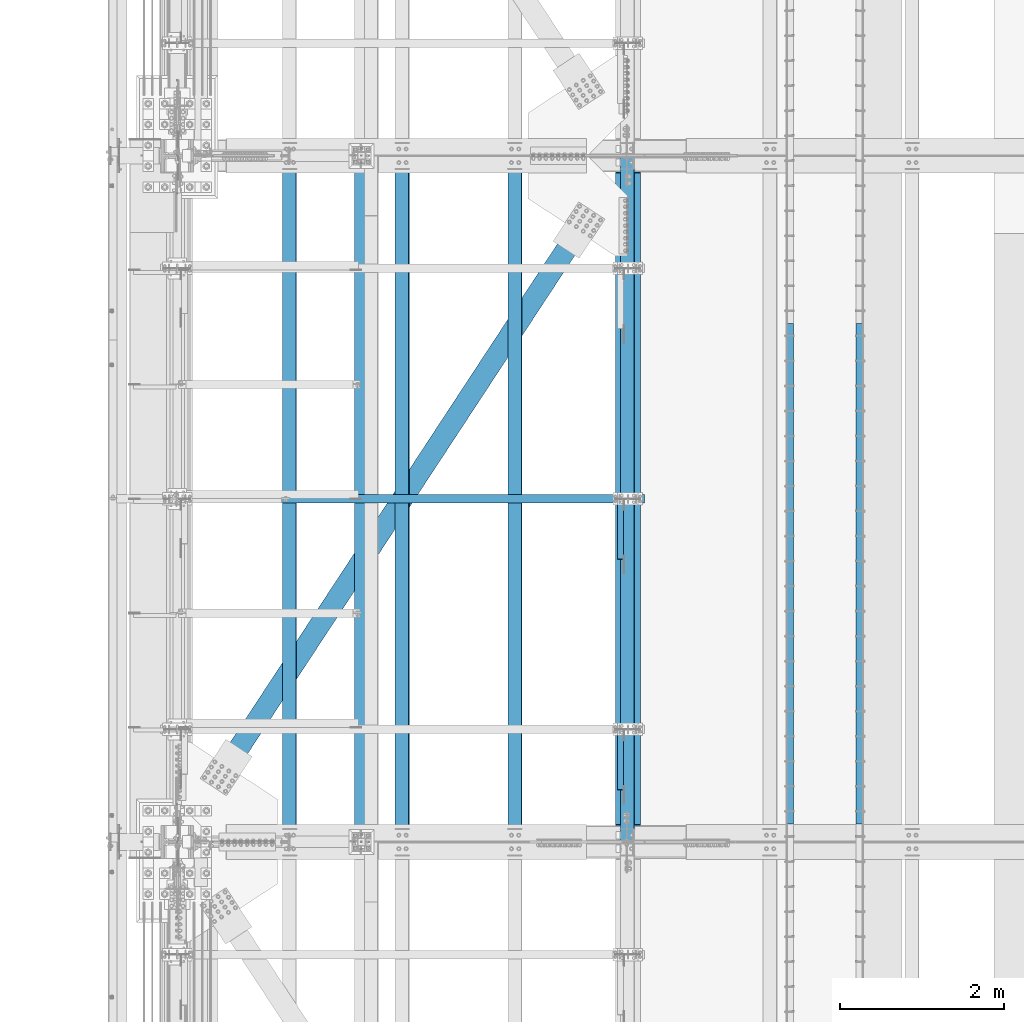
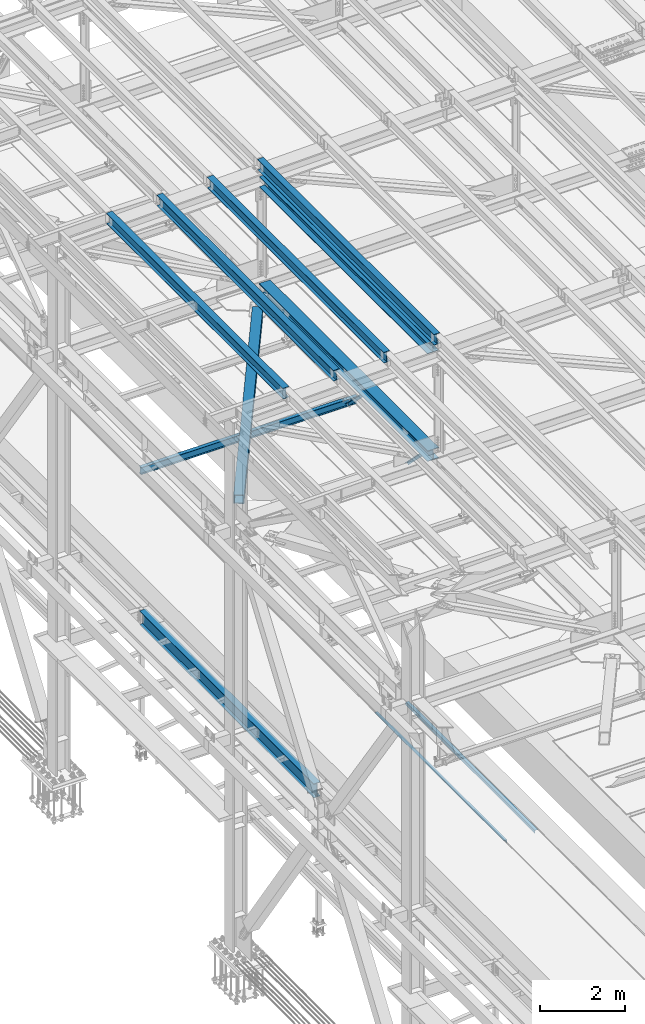
# One storey, part 1821 of 3843: 11 beams, 2 members, 13 elements without a shape of their own.
"""IFC2X3 building model written with IfcOpenShell, lengths in millimetres."""

from ifc_helpers import new_model, si_unit, frame, origin_with_axes, place, context, subcontext, project, spatial, faceted_brep, material, type_object, element, aggregate, save


model = new_model("IFC2X3")

# Units and contexts
model_context = context("Model", 3, precision=1e-05, world=origin_with_axes())
body_context = subcontext(model_context, "Body", "Model", "MODEL_VIEW")
ifc_project = project(units=[si_unit("LENGTHUNIT", "METRE", prefix="MILLI"), si_unit("AREAUNIT", "SQUARE_METRE"), si_unit("VOLUMEUNIT", "CUBIC_METRE"), si_unit("MASSUNIT", "GRAM", prefix="KILO"), si_unit("TIMEUNIT", "SECOND"), si_unit("PLANEANGLEUNIT", "RADIAN"), si_unit("SOLIDANGLEUNIT", "STERADIAN"), si_unit("THERMODYNAMICTEMPERATUREUNIT", "DEGREE_CELSIUS"), si_unit("LUMINOUSINTENSITYUNIT", "LUMEN")], contexts=[model_context])

# Site, building, storey
site_placement = place(None, origin_with_axes())
site = spatial("IfcSite", under=ifc_project, at=site_placement, CompositionType="ELEMENT")
building_placement = place(site_placement, origin_with_axes())
building = spatial("IfcBuilding", under=site, at=building_placement, Name="Undefined", CompositionType="ELEMENT")
storey_placement = place(building_placement, origin_with_axes())
storey = spatial("IfcBuildingStorey", under=building, at=storey_placement, Name="Undefined", CompositionType="ELEMENT", Elevation=0.0)

# Assembly, beam
assembly_1_placement = place(storey_placement, origin_with_axes())
assembly_1 = element("IfcElementAssembly", 1, at=assembly_1_placement, inside=storey, Name="EMBED_ANGLE", AssemblyPlace="NOTDEFINED", PredefinedType="RIGID_FRAME")
ifc_material_1 = material(Name="STEEL/A36")
beam_type_1 = type_object("IfcBeamType", Name="L3-1/2X3-1/2X5/16", PredefinedType="NOTDEFINED")
beam_1_placement = place(assembly_1_placement, frame((44887.896, 65230.375, 30419.675), z_axis=(0.0, 0.0, -1.0), x_axis=(0.0, -1.0, 0.0)))
beam_1 = element("IfcBeam", 2, at=beam_1_placement, type_object=beam_type_1, material=ifc_material_1, Name="EMBED_ANGLE", ObjectType="L3-1/2X3-1/2X5/16", context=body_context, shape_type="Brep", body=[
    faceted_brep([(-3.63797880709171e-12, 44.4499999999971, -44.4500000000007), (-3.63797880709171e-12, 44.4499999999971, 44.4500000000007), (6096.0, 44.4499999999971, 44.4500000000007), (6096.0, 44.4499999999971, -44.4500000000007), (-3.63797880709171e-12, 36.5124999999971, 44.4500000000007), (6096.0, 36.5124999999971, 44.4500000000007), (-3.63797880709171e-12, 36.5124999999971, -36.5125000000007), (6096.0, 36.5124999999971, -36.5125000000007), (3.63797880709171e-12, -44.4499999999971, -36.5125000000007), (6096.0, -44.4499999999971, -36.5125000000007), (3.63797880709171e-12, -44.4499999999971, -44.4500000000007), (6096.0, -44.4499999999971, -44.4500000000007)], [[[0, 1, 2, 3]], [[1, 4, 5, 2]], [[4, 6, 7, 5]], [[6, 8, 9, 7]], [[8, 10, 11, 9]], [[10, 0, 3, 11]], [[5, 7, 9, 11, 3, 2]], [[10, 8, 6, 4, 1, 0]]]),
])
aggregate(assembly_1, [beam_1])

assembly_2_placement = place(storey_placement, origin_with_axes())
assembly_2 = element("IfcElementAssembly", 3, at=assembly_2_placement, inside=storey, Name="EMBED_ANGLE", AssemblyPlace="NOTDEFINED", PredefinedType="RIGID_FRAME")
beam_2_placement = place(assembly_2_placement, frame((44036.996, 59134.375, 30419.675), z_axis=(0.0, 0.0, -1.0), x_axis=(0.0, 1.0, 0.0)))
beam_2 = element("IfcBeam", 4, at=beam_2_placement, type_object=beam_type_1, material=ifc_material_1, Name="EMBED_ANGLE", ObjectType="L3-1/2X3-1/2X5/16", context=body_context, shape_type="Brep", body=[
    faceted_brep([(-3.63797880709171e-12, 44.4499999999971, -44.4500000000007), (-3.63797880709171e-12, 44.4499999999971, 44.4500000000007), (6096.0, 44.4499999999971, 44.4500000000007), (6096.0, 44.4499999999971, -44.4500000000007), (-3.63797880709171e-12, 36.5124999999971, 44.4500000000007), (6096.0, 36.5124999999971, 44.4500000000007), (-3.63797880709171e-12, 36.5124999999971, -36.5125000000007), (6096.0, 36.5124999999971, -36.5125000000007), (3.63797880709171e-12, -44.4499999999971, -36.5125000000007), (6096.0, -44.4499999999971, -36.5125000000007), (3.63797880709171e-12, -44.4499999999971, -44.4500000000007), (6096.0, -44.4499999999971, -44.4500000000007)], [[[0, 1, 2, 3]], [[1, 4, 5, 2]], [[4, 6, 7, 5]], [[6, 8, 9, 7]], [[8, 10, 11, 9]], [[10, 0, 3, 11]], [[5, 7, 9, 11, 3, 2]], [[10, 8, 6, 4, 1, 0]]]),
])
aggregate(assembly_2, [beam_2])

assembly_3_placement = place(storey_placement, origin_with_axes())
assembly_3 = element("IfcElementAssembly", 5, at=assembly_3_placement, inside=storey, Name="BEAM", AssemblyPlace="NOTDEFINED", PredefinedType="RIGID_FRAME")
ifc_material_2 = material(Name="STEEL/A992")
beam_type_2 = type_object("IfcBeamType", Name="W12X26", PredefinedType="NOTDEFINED")
beam_3_placement = place(assembly_3_placement, frame((42059.1092623547, 58915.3115123161, 45721.2578981457), z_axis=(-0.0211520980636923, 7.39979999707428e-05, 0.999776266607585), x_axis=(2.20000000365173e-08, 0.99999999726089, -7.40150000196403e-05)))
beam_3 = element("IfcBeam", 6, at=beam_3_placement, type_object=beam_type_2, material=ifc_material_2, Name="BEAM", ObjectType="W12X26", context=body_context, shape_type="Brep", body=[
    faceted_brep([(12.700127520533, 82.5499999994863, -155.575000000135), (12.6994226809475, 82.5499999995009, -146.050000000127), (8343.89944555684, 82.5499999785316, -146.049999991839), (8343.90012297995, 82.5500000002939, -155.575000022138), (12.6993001598748, 3.17499999966822, -146.050000000112), (8343.89932303577, 3.17499997869163, -146.049999991832), (12.6776850792739, 3.17500000025757, 146.050000000127), (8343.87770795517, 3.17499997927371, 146.050000008421), (12.6778076003466, 82.5500000000975, 146.050000000127), (8343.87783047623, 82.5499999791282, 146.050000008399), (12.677102760761, 82.5500000001193, 155.575000000135), (8343.87712563665, 82.5499999791427, 155.575000008423), (12.6768479169405, -82.5499999995591, 155.575000000157), (8343.87687079283, -82.5500000205429, 155.575000008437), (12.6775527565187, -82.5499999995809, 146.050000000148), (8343.87757563241, -82.5500000205502, 146.050000008436), (12.6776752775913, -3.17499999974098, 146.050000000134), (8343.87769815348, -3.17500002070301, 146.050000008421), (12.6992903581922, -3.17500000032305, -146.050000000112), (8343.89931323408, -3.17500002129964, -146.049999991832), (12.6991678371196, -82.5500000001703, -146.050000000097), (8343.899190713, -82.5500000211468, -146.04999999181), (12.6998726767124, -82.5500000001921, -155.575000000106), (8343.89993364123, -82.5499999997992, -155.575000026431)], [[[0, 1, 2, 3]], [[1, 4, 5, 2]], [[4, 6, 7, 5]], [[6, 8, 9, 7]], [[8, 10, 11, 9]], [[10, 12, 13, 11]], [[12, 14, 15, 13]], [[14, 16, 17, 15]], [[16, 18, 19, 17]], [[18, 20, 21, 19]], [[20, 22, 23, 21]], [[22, 0, 3, 23]], [[5, 7, 9, 11, 13, 15, 17, 19, 21, 23, 3, 2]], [[22, 20, 18, 16, 14, 12, 10, 8, 6, 4, 1, 0]]]),
])
aggregate(assembly_3, [beam_3])

assembly_4_placement = place(storey_placement, origin_with_axes())
assembly_4 = element("IfcElementAssembly", 7, at=assembly_4_placement, inside=storey, Name="BEAM", AssemblyPlace="NOTDEFINED", PredefinedType="RIGID_FRAME")
beam_4_placement = place(assembly_4_placement, frame((40687.5092579516, 58915.3100417598, 45684.997575424), z_axis=(-0.0211520980514033, 6.45460000159801e-05, 0.99977626726275), x_axis=(9.99999685702628e-10, 0.999999997915939, -6.4560999994713e-05)))
beam_4 = element("IfcBeam", 8, at=beam_4_placement, type_object=beam_type_2, material=ifc_material_2, Name="BEAM", ObjectType="W12X26", context=body_context, shape_type="Brep", body=[
    faceted_brep([(12.70011274836, 82.5499999994863, -155.57500000039), (12.6994979422379, 82.5499999995081, -146.050000000389), (8343.89951535721, 82.5500000257598, -146.049999983188), (8343.90012297995, 82.5500000002939, -155.575000022138), (12.699389626614, 3.17499999963911, -146.050000000141), (8343.89940704162, 3.17500002588349, -146.049999982948), (12.6805355721299, 3.17500000042492, 146.05000000017), (8343.88055298712, 3.17500002667657, 146.050000017363), (12.6806438877466, 82.5500000003012, 146.049999999923), (8343.88066130275, 82.5500000265529, 146.050000017116), (12.6800290816172, 82.5500000003303, 155.574999999932), (8343.88004649661, 82.5500000265747, 155.575000017125), (12.6798037851258, -82.5499999994063, 155.575000000455), (8343.87982120013, -82.5499999731546, 155.575000017634), (12.6804185912551, -82.5499999994281, 146.050000000432), (8343.88043600626, -82.549999973191, 146.050000017625), (12.6805269068718, -3.17499999955908, 146.050000000192), (8343.88054432188, -3.17499997330742, 146.050000017378), (12.6993809613632, -3.17500000034488, -146.050000000119), (8343.89939837637, -3.17499997410778, -146.049999982919), (12.6992726457465, -82.5500000002212, -146.049999999872), (8343.89929006073, -82.5499999739768, -146.049999982679), (12.6998726767124, -82.5500000001921, -155.575000000106), (8343.89993364123, -82.5499999997992, -155.575000026431)], [[[0, 1, 2, 3]], [[1, 4, 5, 2]], [[4, 6, 7, 5]], [[6, 8, 9, 7]], [[8, 10, 11, 9]], [[10, 12, 13, 11]], [[12, 14, 15, 13]], [[14, 16, 17, 15]], [[16, 18, 19, 17]], [[18, 20, 21, 19]], [[20, 22, 23, 21]], [[22, 0, 3, 23]], [[5, 7, 9, 11, 13, 15, 17, 19, 21, 23, 3, 2]], [[22, 20, 18, 16, 14, 12, 10, 8, 6, 4, 1, 0]]]),
])
aggregate(assembly_4, [beam_4])

assembly_5_placement = place(storey_placement, origin_with_axes())
assembly_5 = element("IfcElementAssembly", 9, at=assembly_5_placement, inside=storey, Name="BEAM", AssemblyPlace="NOTDEFINED", PredefinedType="RIGID_FRAME")
beam_5_placement = place(assembly_5_placement, frame((39315.9092623368, 58915.2268657565, 45644.0366616244), z_axis=(-0.0211520983455921, -0.000470089999922493, 0.999776158823049), x_axis=(0.0, 0.999999889458325, 0.000470195000215701)))
beam_5 = element("IfcBeam", 10, at=beam_5_placement, type_object=beam_type_2, material=ifc_material_2, Name="BEAM", ObjectType="W12X26", context=body_context, shape_type="Brep", body=[
    faceted_brep([(12.6991634509395, 82.5499999998428, -155.574999999844), (12.70365802179, 82.5500000002357, -146.050000000047), (8343.90457893425, 82.5499999999229, -146.049999985342), (8343.90012297995, 82.5500000002939, -155.575000022138), (12.7044474549184, 3.17500000038126, -146.050000000047), (8343.90536836737, 3.17500000006839, -146.049999985342), (12.8417607012379, 3.17499999960273, 146.05000000009), (8344.04268161369, 3.17499999928987, 146.050000014802), (12.8409712681168, 82.5499999994499, 146.050000000097), (8344.04189218057, 82.5499999991443, 146.050000014802), (12.8454488739662, 82.5499999994354, 155.575000000099), (8344.04636978642, 82.5499999991225, 155.575000014811), (12.8470908948802, -82.5500000002648, 155.575000000099), (8344.04801180735, -82.5500000005704, 155.575000014811), (12.8426132890236, -82.5500000002285, 146.05000000009), (8344.04353420148, -82.5500000005413, 146.050000014802), (12.8418238558879, -3.17500000038126, 146.050000000097), (8344.04274476835, -3.17500000069413, 146.050000014802), (12.7045106095684, -3.17499999960273, -146.050000000047), (8343.90543152201, -3.17499999990832, -146.049999985342), (12.705300042704, -82.5499999994572, -146.050000000054), (8343.90622095515, -82.5499999997701, -146.049999985342), (12.700839471705, -82.5500000010798, -155.574999999444), (8343.90174334928, -82.549999999741, -155.574999985343)], [[[0, 1, 2, 3]], [[1, 4, 5, 2]], [[4, 6, 7, 5]], [[6, 8, 9, 7]], [[8, 10, 11, 9]], [[10, 12, 13, 11]], [[12, 14, 15, 13]], [[14, 16, 17, 15]], [[16, 18, 19, 17]], [[18, 20, 21, 19]], [[20, 22, 23, 21]], [[22, 0, 3, 23]], [[5, 7, 9, 11, 13, 15, 17, 19, 21, 23, 3, 2]], [[22, 20, 18, 16, 14, 12, 10, 8, 6, 4, 1, 0]]]),
])
aggregate(assembly_5, [beam_5])

assembly_6_placement = place(storey_placement, origin_with_axes())
assembly_6 = element("IfcElementAssembly", 11, at=assembly_6_placement, inside=storey, Name="BEAM", AssemblyPlace="NOTDEFINED", PredefinedType="RIGID_FRAME")
beam_6_placement = place(assembly_6_placement, frame((37944.3092623367, 58915.3030863265, 45611.2839900745), z_axis=(-0.021152098011531, 1.98379999928875e-05, 0.999776269150336), x_axis=(0.0, 0.999999999803128, -1.98429999957593e-05)))
beam_6 = element("IfcBeam", 12, at=beam_6_placement, type_object=beam_type_2, material=ifc_material_2, Name="BEAM", ObjectType="W12X26", context=body_context, shape_type="Brep", body=[
    faceted_brep([(12.7000000064072, 82.5500000002939, -155.574999999815), (12.6998457456139, 82.550000000163, -146.049999999952), (8343.89984739283, 82.5499999999738, -146.049999990668), (8343.9000648554, 82.5500000011816, -155.575000015211), (12.6998124302409, 3.17500000029395, -146.049999999777), (8343.89981407746, 3.17500000010477, -146.049999990501), (12.6940175870477, 3.17499999969004, 146.049999999814), (8343.89401923426, 3.17499999949359, 146.050000009083), (12.694050902428, 82.5499999995445, 146.049999999639), (8343.89405254964, 82.5499999993554, 146.050000008931), (12.6938619401408, 82.5499999995227, 155.574999999633), (8343.89386358736, 82.5499999993335, 155.575000008917), (12.6937926441678, -82.5500000001921, 155.574999999975), (8343.89379429138, -82.5500000003885, 155.575000009259), (12.6939816064478, -82.5500000001703, 146.049999999988), (8343.89398325365, -82.5500000003667, 146.050000009265), (12.6940149218208, -3.17500000030122, 146.049999999821), (8343.89401656902, -3.17500000049768, 146.050000009098), (12.6998097650139, -3.17499999969004, -146.04999999977), (8343.89981141222, -3.1749999998865, -146.049999990486), (12.6997764496336, -82.5499999995518, -146.04999999961), (8343.89977809684, -82.5499999997483, -146.049999990326), (12.7000000064072, -82.5500000006432, -155.574999999677), (8343.89993364123, -82.5499999997992, -155.575000026431)], [[[0, 1, 2, 3]], [[1, 4, 5, 2]], [[4, 6, 7, 5]], [[6, 8, 9, 7]], [[8, 10, 11, 9]], [[10, 12, 13, 11]], [[12, 14, 15, 13]], [[14, 16, 17, 15]], [[16, 18, 19, 17]], [[18, 20, 21, 19]], [[20, 22, 23, 21]], [[22, 0, 3, 23]], [[5, 7, 9, 11, 13, 15, 17, 19, 21, 23, 3, 2]], [[22, 20, 18, 16, 14, 12, 10, 8, 6, 4, 1, 0]]]),
])
aggregate(assembly_6, [beam_6])

# Assembly, member
assembly_7_placement = place(storey_placement, origin_with_axes())
assembly_7 = element("IfcElementAssembly", 13, at=assembly_7_placement, inside=storey, Name="ANGLE", AssemblyPlace="NOTDEFINED", PredefinedType="RIGID_FRAME")
ifc_material_3 = material(Name="STEEL/A572-50")
member_type = type_object("IfcMemberType", Name="L3X3X1/4", PredefinedType="NOTDEFINED")
member_1_placement = place(assembly_7_placement, frame((41973.5, 59275.1116026705, 42312.1883973087), z_axis=(0.0, -0.707106781186548, -0.707106781186548), x_axis=(5.70000238222118e-08, 0.707106781186546, -0.707106781186546)))
member_1 = element("IfcMember", 14, at=member_1_placement, type_object=member_type, material=ifc_material_3, Name="ANGLE", ObjectType="L3X3X1/4", context=body_context, shape_type="Brep", body=[
    faceted_brep([(1347.88359305813, -38.0999999999985, -31.7499999999272), (1347.88359305813, -38.0999999999985, -38.099999999904), (1347.88359305813, 38.0999999999985, -38.099999999904), (1347.88359305813, 38.0999999999985, 38.099999999904), (1347.88359305813, 31.75, 38.099999999904), (1347.88359305813, 31.75, -31.7499999999272), (357.28359305804, 31.75, 38.0999999999185), (357.283593058051, 31.75, -31.7499999999127), (357.283593058051, -38.0999999999985, -31.7499999999127), (357.283593058044, -38.0999999999985, -38.099999999904), (357.283593058044, 38.0999999999985, -38.099999999904), (357.28359305804, 38.0999999999985, 38.0999999999185)], [[[0, 1, 2, 3, 4, 5]], [[5, 4, 6, 7]], [[0, 5, 7, 8]], [[1, 0, 8, 9]], [[2, 1, 9, 10]], [[3, 2, 10, 11]], [[4, 3, 11, 6]], [[10, 9, 8, 7, 6, 11]]]),
])
aggregate(assembly_7, [member_1])

assembly_8_placement = place(storey_placement, origin_with_axes())
assembly_8 = element("IfcElementAssembly", 15, at=assembly_8_placement, inside=storey, Name="ANGLE", AssemblyPlace="NOTDEFINED", PredefinedType="RIGID_FRAME")
member_2_placement = place(assembly_8_placement, frame((41973.5, 62082.0298349498, 42311.9701650293), z_axis=(0.0, -0.707106781186548, -0.707106781186548), x_axis=(5.70000238222118e-08, 0.707106781186546, -0.707106781186546)))
member_2 = element("IfcMember", 16, at=member_2_placement, type_object=member_type, material=ifc_material_3, Name="ANGLE", ObjectType="L3X3X1/4", context=body_context, shape_type="Brep", body=[
    faceted_brep([(1347.57496600889, -38.0999999999985, -31.7499999999272), (1347.5749660089, -38.0999999999985, -38.099999999904), (1347.5749660089, 38.0999999999985, -38.099999999904), (1347.57496600889, 38.0999999999985, 38.0999999999185), (1347.57496600889, 31.75, 38.0999999999185), (1347.57496600889, 31.75, -31.7499999999272), (356.974966008811, 31.75, 38.099999999904), (356.974966008807, 31.75, -31.7499999999272), (356.974966008807, -38.0999999999985, -31.7499999999272), (356.974966008815, -38.0999999999985, -38.099999999904), (356.974966008815, 38.0999999999985, -38.099999999904), (356.974966008811, 38.0999999999985, 38.099999999904)], [[[0, 1, 2, 3, 4, 5]], [[5, 4, 6, 7]], [[0, 5, 7, 8]], [[1, 0, 8, 9]], [[2, 1, 9, 10]], [[3, 2, 10, 11]], [[4, 3, 11, 6]], [[10, 9, 8, 7, 6, 11]]]),
])
aggregate(assembly_8, [member_2])

# Assembly, beam
assembly_9_placement = place(storey_placement, origin_with_axes())
assembly_9 = element("IfcElementAssembly", 17, at=assembly_9_placement, inside=storey, Name="BEAM", AssemblyPlace="NOTDEFINED", PredefinedType="RIGID_FRAME")
beam_type_3 = type_object("IfcBeamType", Name="W8X13", PredefinedType="NOTDEFINED")
beam_7_placement = place(assembly_9_placement, frame((36372.8, 63093.6, 41402.0), z_axis=(0.0, 0.0, 1.0), x_axis=(1.0, 0.0, 0.0)))
beam_7 = element("IfcBeam", 18, at=beam_7_placement, type_object=beam_type_3, material=ifc_material_2, Name="BEAM", ObjectType="W8X13", context=body_context, shape_type="Brep", body=[
    faceted_brep([(0.0, 50.7999999999993, -101.599999999999), (0.0, 50.7999999999993, -95.25), (5892.8, 50.7999999999993, -95.25), (5892.8, 50.7999999999993, -101.599999999999), (0.0, 3.17499999999927, -95.25), (5892.8, 3.17499999999927, -95.25), (-2.44140610448085e-05, 3.17500000000291, 95.2499999999927), (5892.8, 3.17499999999927, 95.25), (0.0, 50.7999999999993, 95.25), (5892.8, 50.7999999999993, 95.25), (0.0, 50.7999999999993, 101.599999999999), (5892.8, 50.7999999999993, 101.599999999999), (0.0, -50.7999999999993, 101.599999999999), (5892.8, -50.7999999999993, 101.599999999999), (0.0, -50.7999999999993, 95.25), (5892.8, -50.7999999999993, 95.25), (0.0, -3.17499999999927, 95.25), (5892.8, -3.17499999999927, 95.25), (0.0, -3.17499999999927, -95.25), (5892.8, -3.17499999999927, -95.25), (0.0, -50.7999999999993, -95.25), (5892.8, -50.7999999999993, -95.25), (0.0, -50.7999999999993, -101.599999999999), (5892.8, -50.7999999999993, -101.599999999999)], [[[0, 1, 2, 3]], [[1, 4, 5, 2]], [[4, 6, 7, 5]], [[6, 8, 9, 7]], [[8, 10, 11, 9]], [[10, 12, 13, 11]], [[12, 14, 15, 13]], [[14, 16, 17, 15]], [[16, 18, 19, 17]], [[18, 20, 21, 19]], [[20, 22, 23, 21]], [[22, 0, 3, 23]], [[5, 7, 9, 11, 13, 15, 17, 19, 21, 23, 3, 2]], [[22, 20, 18, 16, 14, 12, 10, 8, 6, 4, 1, 0]]]),
])
aggregate(assembly_9, [beam_7])

assembly_10_placement = place(storey_placement, origin_with_axes())
assembly_10 = element("IfcElementAssembly", 19, at=assembly_10_placement, inside=storey, AssemblyPlace="NOTDEFINED", PredefinedType="RIGID_FRAME")
ifc_material_4 = material()
beam_type_4 = type_object("IfcBeamType", Name="HSS10X10X3/4", PredefinedType="NOTDEFINED")
beam_8_placement = place(assembly_10_placement, frame((36576.0, 58915.3, 42246.55), z_axis=(0.83593862902166, -0.548822930014214, 0.0), x_axis=(0.548822930014222, 0.835938629021655, 0.0)))
beam_8 = element("IfcBeam", 20, at=beam_8_placement, type_object=beam_type_4, material=ifc_material_4, ObjectType="HSS10X10X3/4", context=body_context, shape_type="Brep", body=[
    faceted_brep([(1369.67201569193, -1.587499999594, -107.949999999496), (1369.67201569195, -1.587499999594, -126.999999999579), (1117.25951605695, -1.587499999594, -126.999999999757), (1117.25951605695, -1.587499999594, -107.949999999678), (1375.1396053779, -0.499928791308776, -107.949999999489), (1375.13960537792, -0.499928791308776, -126.999999999572), (1379.77480409802, 2.59721197593171, -107.949999999489), (1379.77480409803, 2.59721197593171, -126.999999999572), (1382.87194486529, 7.23241069597861, -107.949999999481), (1382.87194486531, 7.23241069597861, -126.999999999564), (1383.95951607359, 12.6999996189334, -107.949999999485), (1383.9595160736, 12.6999996189334, -126.999999999564), (1382.87194486529, 18.1675893048305, -107.949999999481), (1382.87194486531, 18.1675893048305, -126.999999999564), (1379.77480409802, 22.8027880248774, -107.949999999489), (1379.77480409803, 22.8027880248774, -126.999999999572), (1375.1396053779, 25.8999287921179, -107.949999999489), (1375.13960537792, 25.8999287921179, -126.999999999572), (1369.67201569193, 26.9875000004031, -107.949999999496), (1369.67201569195, 26.9875000004031, -126.999999999579), (1117.25951605695, 26.9875000004031, -107.949999999678), (1117.25951605695, 26.9875000004031, -126.999999999757), (8627.14989429372, -1.58750000023429, -107.949999994337), (8627.14989429373, -1.58750000023429, -126.99999999442), (8621.68230460776, -0.49992879194906, -126.99999999442), (8621.68230460775, -0.49992879194906, -107.949999994337), (8617.04710588766, 2.59721197529143, -126.99999999442), (8617.04710588765, 2.59721197529143, -107.949999994337), (8613.94996512038, 7.23241069533833, -126.999999994431), (8613.94996512036, 7.23241069533833, -107.949999994345), (8612.86239391209, 12.6999996182931, -126.999999994424), (8612.86239391206, 12.6999996182931, -107.949999994345), (8613.94996512038, 18.1675893041902, -126.999999994431), (8613.94996512036, 18.1675893041902, -107.949999994345), (8617.04710588766, 22.8027880242371, -126.99999999442), (8617.04710588765, 22.8027880242371, -107.949999994337), (8621.68230460776, 25.8999287914776, -126.99999999442), (8621.68230460775, 25.8999287914776, -107.949999994337), (8627.14989429373, 26.9874999997628, -126.99999999442), (8627.14989429372, 26.9874999997628, -107.949999994337), (8881.14986728859, 26.9874999997628, -107.949999994152), (8881.14986728859, 26.9874999997628, -126.999999994238), (1117.25951605695, 127.0, -126.999999999757), (1117.25951605696, 127.0, 127.000000001345), (8881.14986728858, 127.0, 127.00000000686), (8881.14986728859, 127.0, -126.999999994238), (8627.14989429356, -1.58750000023429, 127.000000006686), (8627.14989429357, -1.58750000023429, 107.950000006603), (8621.6823046076, -0.49992879194906, 107.950000006599), (8621.68230460759, -0.49992879194906, 127.000000006682), (8617.0471058875, 2.59721197529143, 107.950000006599), (8617.04710588748, 2.59721197529143, 127.000000006675), (8613.94996512021, 7.23241069533833, 107.950000006592), (8613.94996512019, 7.23241069533833, 127.000000006675), (8612.86239391191, 12.6999996182931, 107.950000006588), (8612.8623939119, 12.6999996182931, 127.000000006675), (8613.94996512021, 18.1675893041902, 107.950000006592), (8613.94996512019, 18.1675893041902, 127.000000006675), (8617.0471058875, 22.8027880242371, 107.950000006599), (8617.04710588748, 22.8027880242371, 127.000000006675), (8621.6823046076, 25.8999287914776, 107.950000006599), (8621.68230460759, 25.8999287914776, 127.000000006682), (8627.14989429357, 26.9874999997628, 107.950000006603), (8627.14989429356, 26.9874999997628, 127.000000006686), (8881.14986728858, 26.9874999997628, 127.00000000686), (8881.14986728859, 26.9874999997628, 107.950000006781), (8881.14986728859, 107.949999999997, 107.950000006781), (8881.14986728859, 107.949999999997, -107.949999994152), (1117.25951605696, 107.949999999997, 107.950000001262), (1117.25951605695, 107.949999999997, -107.949999999678), (1117.25951605696, 26.9875000004031, 107.950000001262), (1117.25951605696, 26.9875000004031, 127.000000001345), (1369.67201569177, 26.9875000004031, 107.950000001444), (1369.67201569177, 26.9875000004031, 127.000000001527), (1375.13960537775, 25.8999287921179, 107.950000001451), (1375.13960537774, 25.8999287921179, 127.000000001531), (1379.77480409786, 22.8027880248774, 107.950000001451), (1379.77480409785, 22.8027880248774, 127.000000001534), (1382.87194486514, 18.1675893048305, 107.950000001455), (1382.87194486513, 18.1675893048305, 127.000000001538), (1383.95951607344, 12.6999996189334, 107.950000001448), (1383.95951607342, 12.6999996189334, 127.000000001538), (1382.87194486514, 7.23241069597861, 107.950000001455), (1382.87194486513, 7.23241069597861, 127.000000001538), (1379.77480409786, 2.59721197593171, 107.950000001451), (1379.77480409785, 2.59721197593171, 127.000000001534), (1375.13960537775, -0.499928791308776, 107.950000001451), (1375.13960537774, -0.499928791308776, 127.000000001531), (1369.67201569177, -1.587499999594, 107.950000001444), (1369.67201569177, -1.587499999594, 127.000000001527), (1117.25951605696, -1.587499999594, 107.950000001262), (1117.25951605696, -1.587499999594, 127.000000001345), (1117.25951605696, -107.949999999997, 107.950000001262), (1117.25951605695, -107.949999999997, -107.949999999678), (1117.25951605695, -127.0, -126.999999999757), (1117.25951605696, -127.0, 127.000000001345), (8881.14986728858, -127.0, 127.00000000686), (8881.14989392307, -1.58750000023429, 127.000000006864), (8881.14986728859, -1.58750000023429, 107.950000006781), (8881.14986728859, -107.949999999997, 107.950000006781), (8881.14986728859, -107.949999999997, -107.949999994152), (8881.14989392324, -1.58750000023429, -107.949999994159), (8881.14986728859, -1.58750000023429, -126.999999994238), (8881.14986728859, -127.0, -126.999999994238)], [[[0, 1, 2, 3]], [[4, 5, 1, 0]], [[6, 7, 5, 4]], [[8, 9, 7, 6]], [[10, 11, 9, 8]], [[12, 13, 11, 10]], [[14, 15, 13, 12]], [[16, 17, 15, 14]], [[18, 19, 17, 16]], [[20, 21, 19, 18]], [[22, 23, 24, 25]], [[25, 24, 26, 27]], [[27, 26, 28, 29]], [[29, 28, 30, 31]], [[31, 30, 32, 33]], [[33, 32, 34, 35]], [[35, 34, 36, 37]], [[37, 36, 38, 39]], [[40, 39, 38, 41]], [[42, 43, 44, 45]], [[46, 47, 48, 49]], [[49, 48, 50, 51]], [[51, 50, 52, 53]], [[53, 52, 54, 55]], [[55, 54, 56, 57]], [[57, 56, 58, 59]], [[59, 58, 60, 61]], [[61, 60, 62, 63]], [[64, 63, 62, 65]], [[66, 67, 40, 41, 45, 44, 64, 65]], [[68, 69, 67, 66]], [[43, 42, 21, 20, 69, 68, 70, 71]], [[71, 70, 72, 73]], [[73, 72, 74, 75]], [[75, 74, 76, 77]], [[77, 76, 78, 79]], [[79, 78, 80, 81]], [[81, 80, 82, 83]], [[83, 82, 84, 85]], [[85, 84, 86, 87]], [[87, 86, 88, 89]], [[89, 88, 90, 91]], [[92, 93, 3, 2, 94, 95, 91, 90]], [[49, 51, 53, 55, 57, 59, 61, 63, 64, 44, 43, 71, 73, 75, 77, 79, 81, 83, 85, 87, 89, 91, 95, 96, 97, 46]], [[97, 98, 47, 46]], [[99, 92, 90, 88, 86, 84, 82, 80, 78, 76, 74, 72, 70, 68, 66, 65, 62, 60, 58, 56, 54, 52, 50, 48, 47, 98]], [[93, 92, 99, 100]], [[25, 27, 29, 31, 33, 35, 37, 39, 40, 67, 69, 20, 18, 16, 14, 12, 10, 8, 6, 4, 0, 3, 93, 100, 101, 22]], [[101, 102, 23, 22]], [[103, 94, 2, 1, 5, 7, 9, 11, 13, 15, 17, 19, 21, 42, 45, 41, 38, 36, 34, 32, 30, 28, 26, 24, 23, 102]], [[95, 94, 103, 96]], [[96, 103, 102, 101, 100, 99, 98, 97]]]),
])
aggregate(assembly_10, [beam_8])

assembly_11_placement = place(storey_placement, origin_with_axes())
assembly_11 = element("IfcElementAssembly", 21, at=assembly_11_placement, inside=storey, Name="BEAM", AssemblyPlace="NOTDEFINED", PredefinedType="RIGID_FRAME")
beam_type_5 = type_object("IfcBeamType", Name="W12X65", PredefinedType="NOTDEFINED")
beam_9_placement = place(assembly_11_placement, frame((42062.4, 58915.3, 42277.7905524263), z_axis=(0.0, 7.73699999990641e-05, 0.999999997006942), x_axis=(0.0, 0.999999997006942, -7.73700000017339e-05)))
beam_9 = element("IfcBeam", 22, at=beam_9_placement, type_object=beam_type_5, material=ifc_material_2, Name="BEAM", ObjectType="W12X65", context=body_context, shape_type="Brep", body=[
    faceted_brep([(198.449414607909, 152.400000000001, -153.98750000065), (198.44818635915, 152.400000000001, -138.112500000607), (8158.17321022509, 152.400000000001, -138.112500010437), (8158.17443847385, 152.400000000001, -153.98750001048), (198.44818635915, 4.76249999999709, -138.112500000607), (8158.17321022509, 4.76249999999709, -138.112500010437), (198.42681483084, 4.76249999999709, 138.112500000119), (8158.15183869677, 4.76249999999709, 138.112499990297), (198.42681483084, 152.400000000001, 138.112500000119), (8158.15183869677, 152.400000000001, 138.112499990297), (198.425586582081, 152.400000000001, 153.987500000163), (8158.15061044803, 152.400000000001, 153.987499990333), (198.425586582081, -152.400000000001, 153.987500000163), (8158.15061044803, -152.400000000001, 153.987499990333), (198.42681483084, -152.400000000001, 138.112500000119), (8158.15183869677, -152.400000000001, 138.112499990297), (198.42681483084, -4.76249999999709, 138.112500000119), (8158.15183869677, -4.76249999999709, 138.112499990297), (198.44818635915, -4.76249999999709, -138.112500000607), (8158.17321022509, -4.76249999999709, -138.112500010437), (198.44818635915, -152.400000000001, -138.112500000607), (8158.17321022509, -152.400000000001, -138.112500010437), (198.449414607909, -152.400000000001, -153.98750000065), (8158.17443847385, -152.400000000001, -153.98750001048)], [[[0, 1, 2, 3]], [[1, 4, 5, 2]], [[4, 6, 7, 5]], [[6, 8, 9, 7]], [[8, 10, 11, 9]], [[10, 12, 13, 11]], [[12, 14, 15, 13]], [[14, 16, 17, 15]], [[16, 18, 19, 17]], [[18, 20, 21, 19]], [[20, 22, 23, 21]], [[22, 0, 3, 23]], [[5, 7, 9, 11, 13, 15, 17, 19, 21, 23, 3, 2]], [[22, 20, 18, 16, 14, 12, 10, 8, 6, 4, 1, 0]]]),
])
aggregate(assembly_11, [beam_9])

assembly_12_placement = place(storey_placement, origin_with_axes())
assembly_12 = element("IfcElementAssembly", 23, at=assembly_12_placement, inside=storey, Name="BEAM", AssemblyPlace="NOTDEFINED", PredefinedType="RIGID_FRAME")
beam_10_placement = place(assembly_12_placement, frame((42062.4, 58915.3, 45368.7993947873), z_axis=(0.0, 7.93669999911798e-05, 0.99999999685044), x_axis=(0.0, 0.99999999685044, -7.93669999882834e-05)))
beam_10 = element("IfcBeam", 24, at=beam_10_placement, type_object=beam_type_5, material=ifc_material_2, Name="BEAM", ObjectType="W12X65", context=body_context, shape_type="Brep", body=[
    faceted_brep([(212.737222195537, 152.400000000001, -153.987499999203), (212.735962244413, 152.400000000001, -138.112499999217), (8143.88598720929, 152.400000000001, -138.112499975061), (8143.88724716041, 152.400000000001, -153.987499975046), (212.735962244413, 4.76249999999709, -138.112499999217), (8143.88598720929, 4.76249999999709, -138.112499975061), (212.714039094768, 4.76249999999709, 138.112500000527), (8143.86406405964, 4.76249999999709, 138.112500024683), (212.714039094768, 152.400000000001, 138.112500000527), (8143.86406405964, 152.400000000001, 138.112500024683), (212.712779143643, 152.400000000001, 153.987500000512), (8143.86280410852, 152.400000000001, 153.987500024668), (212.712779143643, -152.400000000001, 153.987500000512), (8143.86280410852, -152.400000000001, 153.987500024668), (212.714039094768, -152.400000000001, 138.112500000527), (8143.86406405964, -152.400000000001, 138.112500024683), (212.714039094768, -4.76249999999709, 138.112500000527), (8143.86406405964, -4.76249999999709, 138.112500024683), (212.735962244413, -4.76249999999709, -138.112499999217), (8143.88598720929, -4.76249999999709, -138.112499975061), (212.735962244413, -152.400000000001, -138.112499999217), (8143.88598720929, -152.400000000001, -138.112499975061), (212.737222195537, -152.400000000001, -153.987499999203), (8143.88724716041, -152.400000000001, -153.987499975046)], [[[0, 1, 2, 3]], [[1, 4, 5, 2]], [[4, 6, 7, 5]], [[6, 8, 9, 7]], [[8, 10, 11, 9]], [[10, 12, 13, 11]], [[12, 14, 15, 13]], [[14, 16, 17, 15]], [[16, 18, 19, 17]], [[18, 20, 21, 19]], [[20, 22, 23, 21]], [[22, 0, 3, 23]], [[5, 7, 9, 11, 13, 15, 17, 19, 21, 23, 3, 2]], [[22, 20, 18, 16, 14, 12, 10, 8, 6, 4, 1, 0]]]),
])
aggregate(assembly_12, [beam_10])

assembly_13_placement = place(storey_placement, origin_with_axes())
assembly_13 = element("IfcElementAssembly", 25, at=assembly_13_placement, inside=storey, Name="BEAM", AssemblyPlace="NOTDEFINED", PredefinedType="RIGID_FRAME")
beam_type_6 = type_object("IfcBeamType", Name="W16X40", PredefinedType="NOTDEFINED")
beam_11_placement = place(assembly_13_placement, frame((38820.725, 58915.3, 33832.8), z_axis=(0.0, 0.0, 1.0), x_axis=(0.0, 1.0, 0.0)))
beam_11 = element("IfcBeam", 26, at=beam_11_placement, type_object=beam_type_6, material=ifc_material_2, Name="BEAM", ObjectType="W16X40", context=body_context, shape_type="Brep", body=[
    faceted_brep([(63.4999999999854, -88.9000000000015, -203.199999999997), (63.4999999999854, 88.9000000000015, -203.199999999997), (8293.09999999999, 88.9000000000015, -203.199999999997), (8293.09999999999, -88.9000000000015, -203.199999999997), (63.4999999999854, -88.9000000000015, -190.5), (63.4999999999854, -3.96875, -190.5), (63.4999999999854, -3.96875, 190.5), (63.4999999999854, -88.9000000000015, 190.5), (63.4999999999854, -88.9000000000015, 203.199999999997), (63.4999999999854, 88.9000000000015, 203.199999999997), (63.4999999999854, 88.9000000000015, 190.5), (63.4999999999854, 3.96875, 190.5), (63.4999999999854, 3.96875, -190.5), (63.4999999999854, 88.9000000000015, -190.5), (8293.09999999999, -88.9000000000015, -190.5), (8293.09999999999, -3.96875, -190.5), (8293.09999999999, -3.96875, 190.5), (8293.09999999999, -88.9000000000015, 190.5), (8293.09999999999, -88.9000000000015, 203.199999999997), (8293.09999999999, 88.9000000000015, 203.199999999997), (8293.09999999999, 88.9000000000015, 190.5), (8293.09999999999, 3.96875, 190.5), (8293.09999999999, 3.96875, -190.5), (8293.09999999999, 88.9000000000015, -190.5)], [[[0, 1, 2, 3]], [[0, 4, 5, 6, 7, 8, 9, 10, 11, 12, 13, 1]], [[5, 4, 14, 15]], [[6, 5, 15, 16]], [[7, 6, 16, 17]], [[8, 7, 17, 18]], [[9, 8, 18, 19]], [[10, 9, 19, 20]], [[11, 10, 20, 21]], [[12, 11, 21, 22]], [[13, 12, 22, 23]], [[1, 13, 23, 2]], [[22, 21, 20, 19, 18, 17, 16, 15, 14, 3, 2, 23]], [[4, 0, 3, 14]]]),
])
aggregate(assembly_13, [beam_11])

save(model, "model.ifc")
